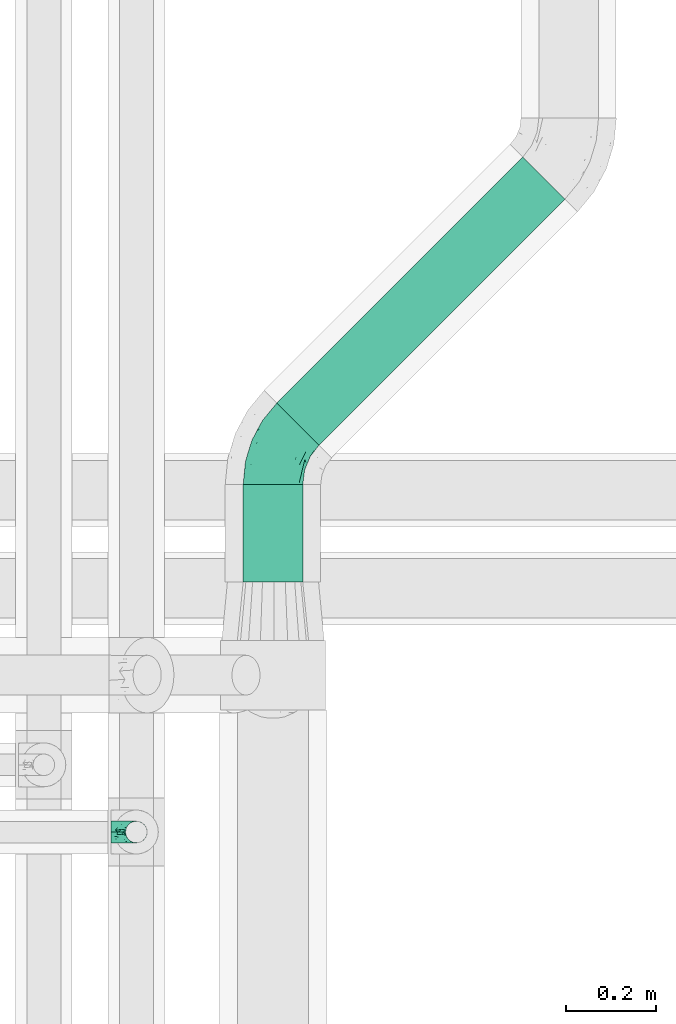
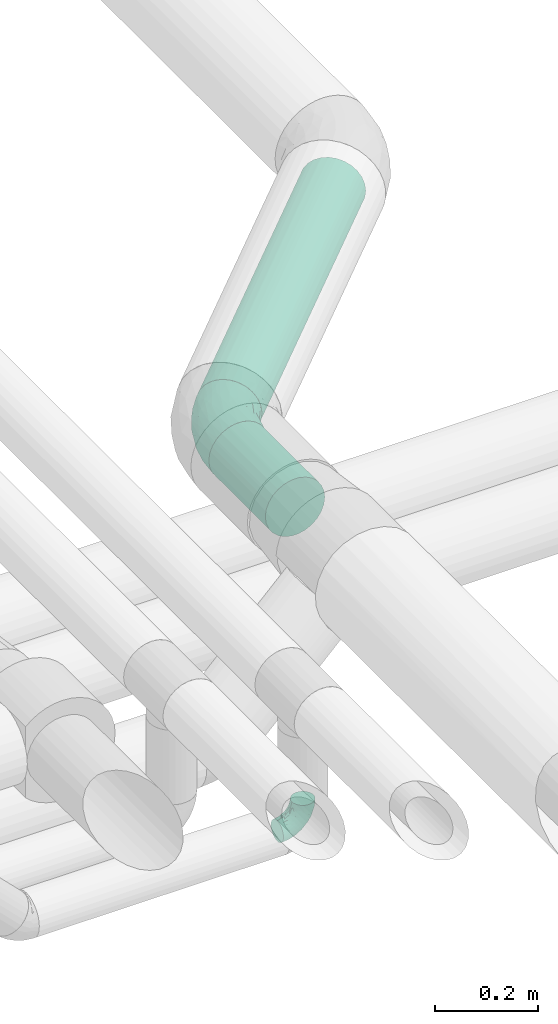
# One storey, part 69 of 93: 2 flow fittings, 2 flow segments.
"""IFC2X3 building model written with IfcOpenShell, lengths in millimetres."""

from ifc_helpers import new_model, entity, si_unit, converted_unit, derived_unit, direction, frame, origin, origin_2d_with_axis, place, context, subcontext, project, spatial, circle, extrude, faceted_brep, source, transform, mapped, material, type_object, type_shapes, element, save


model = new_model("IFC2X3")

# Units and contexts
model_context = context("Model", 3, precision=0.01, world=origin(), true_north=direction((6.12303176911189e-17, 1.0)))
body_context = subcontext(model_context, "Body", "Model", "MODEL_VIEW")
ifc_project = project(units=[si_unit("LENGTHUNIT", "METRE", prefix="MILLI"), si_unit("AREAUNIT", "SQUARE_METRE"), si_unit("VOLUMEUNIT", "CUBIC_METRE"), converted_unit("PLANEANGLEUNIT", "DEGREE", entity("IfcRatioMeasure", 0.0174532925199433), si_unit("PLANEANGLEUNIT", "RADIAN"), dimensions=[0, 0, 0, 0, 0, 0, 0]), si_unit("MASSUNIT", "GRAM", prefix="KILO"), derived_unit("MASSDENSITYUNIT", [(si_unit("MASSUNIT", "GRAM", prefix="KILO"), 1), (si_unit("LENGTHUNIT", "METRE"), -3)]), derived_unit("MOMENTOFINERTIAUNIT", [(si_unit("LENGTHUNIT", "METRE"), 4)]), si_unit("TIMEUNIT", "SECOND"), si_unit("FREQUENCYUNIT", "HERTZ"), si_unit("THERMODYNAMICTEMPERATUREUNIT", "DEGREE_CELSIUS"), derived_unit("THERMALTRANSMITTANCEUNIT", [(si_unit("MASSUNIT", "GRAM", prefix="KILO"), 1), (si_unit("THERMODYNAMICTEMPERATUREUNIT", "KELVIN"), -1), (si_unit("TIMEUNIT", "SECOND"), -3)]), derived_unit("VOLUMETRICFLOWRATEUNIT", [(si_unit("LENGTHUNIT", "METRE"), 3), (si_unit("TIMEUNIT", "SECOND"), -1)]), derived_unit("MASSFLOWRATEUNIT", [(si_unit("MASSUNIT", "GRAM", prefix="KILO"), 1), (si_unit("TIMEUNIT", "SECOND"), -1)]), derived_unit("ROTATIONALFREQUENCYUNIT", [(si_unit("TIMEUNIT", "SECOND"), -1)]), si_unit("ELECTRICCURRENTUNIT", "AMPERE"), si_unit("ELECTRICVOLTAGEUNIT", "VOLT"), si_unit("POWERUNIT", "WATT"), si_unit("FORCEUNIT", "NEWTON", prefix="KILO"), si_unit("ILLUMINANCEUNIT", "LUX"), si_unit("LUMINOUSFLUXUNIT", "LUMEN"), si_unit("LUMINOUSINTENSITYUNIT", "CANDELA"), derived_unit("USERDEFINED", [(si_unit("MASSUNIT", "GRAM", prefix="KILO"), -1), (si_unit("LENGTHUNIT", "METRE"), -2), (si_unit("TIMEUNIT", "SECOND"), 3), (si_unit("LUMINOUSFLUXUNIT", "LUMEN"), 1)]), derived_unit("LINEARVELOCITYUNIT", [(si_unit("LENGTHUNIT", "METRE"), 1), (si_unit("TIMEUNIT", "SECOND"), -1)]), si_unit("PRESSUREUNIT", "PASCAL"), derived_unit("USERDEFINED", [(si_unit("LENGTHUNIT", "METRE"), -2), (si_unit("MASSUNIT", "GRAM", prefix="KILO"), 1), (si_unit("TIMEUNIT", "SECOND"), -2)]), derived_unit("LINEARFORCEUNIT", [(si_unit("MASSUNIT", "GRAM", prefix="KILO"), 1), (si_unit("LENGTHUNIT", "METRE"), 1), (si_unit("TIMEUNIT", "SECOND"), -2), (si_unit("LENGTHUNIT", "METRE"), -1)]), derived_unit("PLANARFORCEUNIT", [(si_unit("MASSUNIT", "GRAM", prefix="KILO"), 1), (si_unit("LENGTHUNIT", "METRE"), 1), (si_unit("TIMEUNIT", "SECOND"), -2), (si_unit("LENGTHUNIT", "METRE"), -2)])], contexts=[model_context])

# Site, building, storey
site_placement = place(None, origin())
site = spatial("IfcSite", under=ifc_project, at=site_placement, CompositionType="ELEMENT")
building_placement = place(site_placement, origin())
building = spatial("IfcBuilding", under=site, at=building_placement, CompositionType="ELEMENT")
storey_placement = place(building_placement, frame((0.0, 0.0, -4200.0)))
storey = spatial("IfcBuildingStorey", under=building, at=storey_placement, CompositionType="ELEMENT", Elevation=-4200.0)

# Flow segments
pipe_segment_type = type_object("IfcPipeSegmentType", PredefinedType="NOTDEFINED")
flow_segment_1_placement = place(storey_placement, frame((24911.2, 9268.64, 2931.9)))
element("IfcFlowSegment", 1, at=flow_segment_1_placement, inside=storey, type_object=pipe_segment_type, context=body_context, shape_type="SweptSolid", body=[
    extrude(circle(Radius=66.5, at=origin_2d_with_axis()), frame((68.1, 0.0, 68.1), z_axis=(0.0, 1.0, 0.0), x_axis=(1.0, 0.0, 0.0)), (0.0, 0.0, 1.0), 218.399081147116),
])
flow_segment_2_placement = place(storey_placement, frame((24986.33, 9572.77, 2931.9)))
element("IfcFlowSegment", 2, at=flow_segment_2_placement, inside=storey, type_object=pipe_segment_type, context=body_context, shape_type="SweptSolid", body=[
    extrude(circle(Radius=66.5, at=origin_2d_with_axis()), frame((48.62, 48.62, 68.1), z_axis=(0.707106781186553, 0.707106781186542, 0.0), x_axis=(0.707106781186542, -0.707106781186553, 0.0)), (0.0, 0.0, 1.0), 775.73593128809),
])

# Flow fittings
ifc_material = material()
pipe_fitting_type_1 = type_object("IfcPipeFittingType", Name="ADSK_2", PredefinedType="NOTDEFINED", material=ifc_material)
shared_shape_1 = source(origin(), body_context, "Body", "Brep", [
    faceted_brep([(-78.7, 33.25, -57.59), (-78.7, 17.21, -64.23), (-78.7, 0.0, -66.5), (-78.7, -17.21, -64.23), (-78.7, -33.25, -57.59), (-78.7, -47.02, -47.02), (-78.7, -57.59, -33.25), (-78.7, -64.23, -17.21), (-78.7, -66.5, 0.0), (-78.7, -64.23, 17.21), (-78.7, -57.59, 33.25), (-78.7, -47.02, 47.02), (-78.7, -33.25, 57.59), (-78.7, -17.21, 64.23), (-78.7, 0.0, 66.5), (-78.7, 17.21, 64.23), (-78.7, 33.25, 57.59), (-78.7, 47.02, 47.02), (-78.7, 57.59, 33.25), (-78.7, 64.23, 17.21), (-78.7, 66.5, 0.0), (-78.7, 64.23, -17.21), (-78.7, 57.59, -33.25), (-78.7, 47.02, -47.02), (55.65, 55.65, -66.5), (43.48, 67.82, -64.23), (32.14, 79.16, -57.59), (22.4, 88.9, -47.02), (14.93, 96.37, -33.25), (10.23, 101.07, -17.21), (8.63, 102.67, 0.0), (10.23, 101.07, 17.21), (14.93, 96.37, 33.25), (22.4, 88.9, 47.02), (32.14, 79.16, 57.59), (43.48, 67.82, 64.23), (55.65, 55.65, 66.5), (67.82, 43.48, 64.23), (79.16, 32.14, 57.59), (88.9, 22.4, 47.02), (96.37, 14.93, 33.25), (101.07, 10.23, 17.21), (102.67, 8.63, 0.0), (101.07, 10.23, -17.21), (96.37, 14.93, -33.25), (88.9, 22.4, -47.02), (79.16, 32.14, -57.59), (67.82, 43.48, -64.23), (-40.01, -57.38, 27.86), (-40.6, -61.75, 15.74), (-6.41, -52.87, 20.07), (-28.66, -61.57, 0.0), (44.74, 12.16, 61.0), (-23.71, -35.12, 51.77), (8.73, -21.07, 54.25), (-40.23, -23.04, 61.0), (-34.61, -49.5, 39.47), (-28.9, -3.87, 65.72), (-8.47, 20.45, 66.18), (-47.15, 10.46, 66.05), (-49.81, 55.22, 41.25), (-33.77, 66.88, 30.79), (-20.88, 50.42, 53.92), (7.4, 48.4, 61.91), (-34.71, 30.07, 61.97), (42.4, -35.06, 11.04), (19.46, -46.98, 0.0), (63.8, -23.27, 0.0), (-15.18, 67.35, 41.6), (14.82, -35.78, 38.27), (53.98, -24.32, 23.88), (-30.55, 73.76, 17.41), (-46.74, 70.71, 0.0), (59.47, -10.53, 39.47), (-16.95, 83.05, 0.0), (25.95, 40.74, 66.05), (41.59, -8.07, 51.77), (23.18, 17.7, 65.72), (74.36, -14.41, 12.26), (4.62, -11.15, 60.44), (-39.45, 28.99, -61.91), (-20.88, 50.42, -53.92), (3.28, 45.81, -61.97), (-23.41, 71.18, -30.79), (8.73, -21.07, -54.25), (4.62, -11.15, -60.44), (44.74, 12.16, -61.0), (-30.55, 73.76, -17.41), (-40.23, -23.04, -61.0), (-23.71, -35.12, -51.77), (-36.89, 58.36, -41.6), (-47.15, 10.46, -66.05), (-28.9, -3.87, -65.72), (-20.98, -55.37, -23.88), (-34.61, -49.5, -39.47), (68.86, -12.28, -27.86), (59.47, -10.53, -39.47), (-42.39, -62.77, -12.26), (41.59, -8.07, -51.77), (14.82, -35.78, -38.27), (41.92, -32.85, -20.07), (-5.19, -54.78, -11.04), (72.37, -14.95, -15.74), (-3.83, 74.27, -41.25), (25.95, 40.74, -66.05), (23.18, 17.7, -65.72), (-8.47, 20.45, -66.18)], [[[0, 1, 2, 3, 4, 5, 6, 7, 8, 9, 10, 11, 12, 13, 14, 15, 16, 17, 18, 19, 20, 21, 22, 23]], [[24, 25, 26, 27, 28, 29, 30, 31, 32, 33, 34, 35, 36, 37, 38, 39, 40, 41, 42, 43, 44, 45, 46, 47]], [[48, 49, 50]], [[49, 8, 51]], [[38, 37, 52]], [[12, 11, 53]], [[53, 54, 55]], [[56, 11, 10]], [[14, 13, 57]], [[13, 12, 55]], [[57, 58, 59]], [[60, 61, 18]], [[62, 63, 34]], [[18, 61, 19]], [[16, 15, 64]], [[17, 16, 62]], [[65, 66, 67]], [[60, 62, 68]], [[15, 14, 59]], [[34, 33, 62]], [[69, 50, 70]], [[19, 71, 72]], [[40, 39, 73]], [[72, 20, 19]], [[74, 71, 31]], [[50, 66, 65]], [[62, 16, 64]], [[56, 48, 69]], [[66, 50, 51]], [[36, 35, 75]], [[39, 38, 76]], [[76, 73, 39]], [[32, 31, 61]], [[75, 77, 36]], [[70, 41, 40]], [[77, 37, 36]], [[48, 56, 10]], [[70, 40, 73]], [[59, 64, 15]], [[76, 38, 52]], [[58, 75, 63]], [[42, 41, 78]], [[53, 56, 69]], [[17, 60, 18]], [[54, 79, 55]], [[72, 71, 74]], [[48, 9, 49]], [[30, 74, 31]], [[54, 69, 76]], [[31, 71, 61]], [[58, 57, 77]], [[32, 68, 33]], [[55, 57, 13]], [[68, 62, 33]], [[79, 52, 77]], [[35, 34, 63]], [[63, 62, 64]], [[73, 76, 69]], [[79, 77, 57]], [[78, 70, 65]], [[70, 73, 69]], [[56, 53, 11]], [[58, 63, 64]], [[53, 55, 12]], [[57, 55, 79]], [[77, 52, 37]], [[52, 79, 54]], [[57, 59, 14]], [[64, 59, 58]], [[63, 75, 35]], [[77, 75, 58]], [[62, 60, 17]], [[61, 60, 68]], [[32, 61, 68]], [[61, 71, 19]], [[9, 48, 10]], [[69, 48, 50]], [[8, 49, 9]], [[51, 50, 49]], [[78, 65, 67]], [[50, 65, 70]], [[42, 78, 67]], [[70, 78, 41]], [[69, 54, 53]], [[52, 54, 76]], [[1, 0, 80]], [[81, 82, 80]], [[28, 83, 29]], [[23, 81, 0]], [[20, 72, 21]], [[84, 85, 86]], [[21, 87, 83]], [[88, 89, 4]], [[81, 23, 90]], [[91, 92, 2]], [[26, 25, 82]], [[91, 2, 1]], [[93, 6, 94]], [[95, 96, 44]], [[8, 7, 97]], [[81, 80, 0]], [[93, 7, 6]], [[98, 96, 99]], [[88, 4, 3]], [[100, 66, 101]], [[6, 5, 94]], [[89, 5, 4]], [[2, 92, 3]], [[94, 89, 99]], [[93, 94, 99]], [[96, 98, 45]], [[87, 72, 74]], [[89, 94, 5]], [[74, 30, 29]], [[99, 100, 93]], [[72, 87, 21]], [[95, 43, 102]], [[103, 83, 28]], [[90, 103, 81]], [[26, 82, 81]], [[46, 45, 98]], [[104, 25, 24]], [[96, 95, 99]], [[22, 90, 23]], [[26, 81, 27]], [[84, 99, 89]], [[104, 105, 106]], [[84, 86, 98]], [[27, 103, 28]], [[24, 47, 105]], [[67, 66, 100]], [[44, 96, 45]], [[47, 46, 86]], [[100, 95, 102]], [[85, 92, 105]], [[67, 102, 42]], [[85, 88, 92]], [[106, 105, 92]], [[97, 93, 101]], [[22, 21, 83]], [[101, 66, 51]], [[104, 82, 25]], [[87, 74, 29]], [[106, 91, 80]], [[86, 105, 47]], [[106, 80, 82]], [[92, 88, 3]], [[88, 85, 84]], [[98, 86, 46]], [[105, 86, 85]], [[80, 91, 1]], [[92, 91, 106]], [[105, 104, 24]], [[82, 104, 106]], [[81, 103, 27]], [[83, 103, 90]], [[22, 83, 90]], [[83, 87, 29]], [[43, 95, 44]], [[99, 95, 100]], [[42, 102, 43]], [[67, 100, 102]], [[97, 101, 51]], [[100, 101, 93]], [[8, 97, 51]], [[93, 97, 7]], [[99, 84, 98]], [[88, 84, 89]]]),
])
type_shapes(pipe_fitting_type_1, [shared_shape_1])
flow_fitting_1_placement = place(storey_placement, frame((24979.3, 9565.74, 3000.0), z_axis=(0.0, 0.0, 1.0), x_axis=(-0.707106781186546, -0.70710678118655, 0.0)))
element("IfcFlowFitting", 3, at=flow_fitting_1_placement, inside=storey, type_object=pipe_fitting_type_1, material=ifc_material, Name="ADSK_2", ObjectType="ADSK_2", context=body_context, shape_type="MappedRepresentation", body=[
    mapped(shared_shape_1, transform((0.0, 0.0, 0.0), scale=1.0)),
])
pipe_fitting_type_2 = type_object("IfcPipeFittingType", Name="ADSK_1", PredefinedType="NOTDEFINED", material=ifc_material)
shared_shape_2 = source(origin(), body_context, "Body", "Brep", [
    faceted_brep([(-57.0, 12.07, -20.91), (-57.0, 6.25, -23.33), (-57.0, 0.0, -24.15), (-57.0, -6.25, -23.33), (-57.0, -12.08, -20.91), (-57.0, -17.08, -17.08), (-57.0, -20.91, -12.08), (-57.0, -23.33, -6.25), (-57.0, -24.15, 0.0), (-57.0, -23.33, 6.25), (-57.0, -20.91, 12.07), (-57.0, -17.08, 17.08), (-57.0, -12.08, 20.91), (-57.0, -6.25, 23.33), (-57.0, 0.0, 24.15), (-57.0, 6.25, 23.33), (-57.0, 12.07, 20.91), (-57.0, 17.08, 17.08), (-57.0, 20.91, 12.07), (-57.0, 23.33, 6.25), (-57.0, 24.15, 0.0), (-57.0, 23.33, -6.25), (-57.0, 20.91, -12.08), (-57.0, 17.08, -17.08), (0.0, 57.0, -24.15), (-6.25, 57.0, -23.33), (-12.07, 57.0, -20.91), (-17.08, 57.0, -17.08), (-20.91, 57.0, -12.08), (-23.33, 57.0, -6.25), (-24.15, 57.0, 0.0), (-23.33, 57.0, 6.25), (-20.91, 57.0, 12.07), (-17.08, 57.0, 17.08), (-12.07, 57.0, 20.91), (-6.25, 57.0, 23.33), (0.0, 57.0, 24.15), (6.25, 57.0, 23.33), (12.08, 57.0, 20.91), (17.08, 57.0, 17.08), (20.91, 57.0, 12.07), (23.33, 57.0, 6.25), (24.15, 57.0, 0.0), (23.33, 57.0, -6.25), (20.91, 57.0, -12.08), (17.08, 57.0, -17.08), (12.08, 57.0, -20.91), (6.25, 57.0, -23.33), (14.9, 21.14, 6.17), (13.61, 24.64, 12.48), (6.23, 8.95, 8.98), (-41.47, -21.06, 0.0), (-41.92, -18.38, 13.72), (-24.64, -13.61, 12.48), (-37.37, -13.24, 18.15), (-6.8, -4.93, 8.18), (-21.76, -15.19, 6.22), (-12.78, -9.18, 0.0), (-37.73, -20.51, 7.75), (-7.38, 7.38, 20.24), (-23.37, -4.26, 20.42), (-11.9, -3.19, 15.86), (-42.14, -8.7, 21.82), (13.24, 37.37, 18.15), (9.33, 23.53, 16.85), (4.26, 23.37, 20.42), (2.77, 10.92, 15.55), (-29.46, 0.91, 23.52), (-44.13, 20.56, 15.69), (-39.25, 26.33, 10.88), (-49.02, 22.92, 9.96), (-34.58, 23.87, 17.15), (-15.8, 6.8, 22.81), (-8.67, 20.47, 23.88), (-18.12, 12.9, 24.08), (-48.29, 14.92, 19.65), (-44.06, -2.85, 23.78), (-9.23, 48.95, 22.58), (-3.78, 42.74, 24.07), (-40.34, 4.26, 24.09), (-44.02, 26.14, 5.46), (-44.04, 9.88, 22.74), (-4.95, 16.87, 22.52), (-2.75, 1.43, 12.5), (-25.48, 40.98, 10.71), (20.51, 37.73, 7.75), (18.38, 41.92, 13.72), (8.7, 42.14, 21.82), (-25.95, -17.97, 0.0), (2.85, 44.06, 23.78), (21.06, 41.47, 0.0), (17.97, 25.95, 0.0), (-24.04, -9.27, 17.13), (-33.26, 33.26, 5.86), (-28.55, 40.57, 0.0), (-40.57, 28.55, 0.0), (-25.29, 47.19, 4.06), (-27.01, 31.1, 16.77), (-15.7, 43.95, 19.9), (-20.27, 45.22, 15.61), (-30.53, 31.98, 12.64), (-11.28, 38.33, 22.92), (-9.97, 27.88, 24.09), (-20.15, 30.26, 21.25), (-31.25, 11.75, 23.64), (-28.75, 7.23, 24.15), (-29.53, 18.06, 22.27), (-28.44, 24.21, 20.02), (-37.55, 17.7, 20.26), (-15.88, 29.25, 22.99), (-20.82, 20.82, 23.44), (-0.91, 29.46, 23.52), (-13.5, -7.67, 12.04), (1.49, 1.56, 5.16), (8.86, 10.35, 4.59), (0.38, -0.38, 0.0), (9.18, 12.78, 0.0), (-37.37, -13.24, -18.15), (8.86, 10.35, -4.59), (-45.22, 20.27, -15.61), (-43.95, 15.7, -19.9), (-38.33, 11.28, -22.92), (-48.95, 9.23, -22.58), (-47.19, 25.29, -4.06), (-33.26, 33.26, -5.86), (18.38, 41.92, -13.72), (-30.26, 20.15, -21.25), (2.85, 44.06, -23.78), (-4.26, 40.34, -24.09), (-40.98, 25.48, -10.71), (-41.92, -18.38, -13.72), (9.25, 23.5, -16.92), (4.26, 23.37, -20.42), (13.24, 37.37, -18.15), (-37.73, -20.51, -7.75), (-11.75, 31.25, -23.64), (-7.23, 28.75, -24.15), (-12.9, 18.12, -24.08), (8.7, 42.14, -21.82), (-44.06, -2.85, -23.78), (-6.8, 15.8, -22.81), (-20.47, 8.67, -23.88), (-24.64, -13.61, -12.48), (-42.74, 3.78, -24.07), (-18.06, 29.53, -22.27), (-24.21, 28.44, -20.02), (-27.88, 9.97, -24.09), (-31.1, 27.01, -16.77), (-26.14, 44.02, -5.46), (14.9, 21.14, -6.17), (20.51, 37.73, -7.75), (-9.88, 44.04, -22.74), (-20.56, 44.13, -15.69), (-21.76, -15.19, -6.22), (-13.5, -7.67, -12.04), (-24.14, -9.76, -16.74), (-11.9, -3.19, -15.86), (-14.92, 48.29, -19.65), (-23.37, -4.26, -20.42), (-0.91, 29.46, -23.52), (-26.33, 39.25, -10.88), (-23.87, 34.58, -17.15), (-42.14, -8.7, -21.82), (-22.92, 49.02, -9.96), (13.61, 24.64, -12.48), (-31.98, 30.53, -12.64), (-16.87, 4.95, -22.52), (-17.7, 37.55, -20.26), (-29.25, 15.88, -22.99), (-20.82, 20.82, -23.44), (-29.46, 0.91, -23.52), (-7.38, 7.38, -20.24), (2.77, 10.92, -15.55), (6.23, 8.95, -8.98), (-6.8, -4.93, -8.18), (-2.81, 1.41, -12.54), (1.49, 1.56, -5.16)], [[[0, 1, 2, 3, 4, 5, 6, 7, 8, 9, 10, 11, 12, 13, 14, 15, 16, 17, 18, 19, 20, 21, 22, 23]], [[24, 25, 26, 27, 28, 29, 30, 31, 32, 33, 34, 35, 36, 37, 38, 39, 40, 41, 42, 43, 44, 45, 46, 47]], [[48, 49, 50]], [[9, 8, 51]], [[52, 53, 54]], [[55, 56, 57]], [[10, 58, 52]], [[9, 58, 10]], [[59, 60, 61]], [[54, 12, 11]], [[54, 62, 12]], [[63, 39, 38]], [[64, 65, 66]], [[62, 60, 67]], [[68, 69, 70]], [[71, 69, 68]], [[72, 73, 74]], [[16, 75, 17]], [[13, 76, 14]], [[35, 77, 78]], [[14, 79, 15]], [[17, 68, 18]], [[14, 76, 79]], [[20, 19, 80]], [[70, 19, 18]], [[81, 15, 79]], [[15, 81, 16]], [[73, 72, 82]], [[66, 83, 50]], [[32, 31, 84]], [[85, 86, 49]], [[63, 87, 65]], [[56, 58, 88]], [[36, 89, 37]], [[85, 41, 40]], [[36, 35, 78]], [[90, 41, 85]], [[40, 39, 86]], [[12, 62, 13]], [[86, 85, 40]], [[48, 85, 49]], [[85, 91, 90]], [[87, 38, 37]], [[92, 60, 54]], [[80, 69, 93]], [[93, 94, 95]], [[10, 52, 11]], [[94, 96, 30]], [[97, 98, 99]], [[80, 93, 95]], [[100, 97, 84]], [[99, 98, 33]], [[101, 102, 78]], [[103, 101, 98]], [[96, 31, 30]], [[77, 98, 101]], [[77, 35, 34]], [[34, 33, 98]], [[9, 51, 58]], [[87, 63, 38]], [[104, 105, 74]], [[106, 103, 107]], [[106, 81, 104]], [[75, 68, 17]], [[108, 107, 71]], [[33, 32, 99]], [[109, 103, 110]], [[101, 109, 102]], [[89, 78, 111]], [[53, 52, 58]], [[54, 11, 52]], [[60, 62, 54]], [[88, 58, 51]], [[76, 62, 67]], [[53, 112, 92]], [[60, 59, 72]], [[39, 63, 86]], [[49, 86, 63]], [[89, 87, 37]], [[42, 41, 90]], [[111, 82, 65]], [[111, 65, 87]], [[65, 59, 66]], [[104, 81, 79]], [[75, 81, 108]], [[32, 84, 99]], [[97, 99, 84]], [[98, 97, 103]], [[106, 107, 108]], [[74, 102, 110]], [[111, 78, 102]], [[74, 110, 104]], [[74, 67, 72]], [[61, 92, 112]], [[66, 59, 61]], [[56, 53, 58]], [[66, 50, 49]], [[61, 112, 83]], [[66, 49, 64]], [[78, 89, 36]], [[87, 89, 111]], [[62, 76, 13]], [[79, 76, 67]], [[100, 93, 69]], [[96, 93, 84]], [[55, 113, 50]], [[113, 114, 50]], [[104, 79, 105]], [[106, 104, 110]], [[20, 80, 95]], [[85, 48, 91]], [[115, 114, 113]], [[116, 91, 48]], [[70, 80, 19]], [[93, 96, 94]], [[84, 31, 96]], [[103, 106, 110]], [[81, 106, 108]], [[103, 97, 107]], [[71, 107, 97]], [[71, 97, 100]], [[108, 71, 68]], [[79, 67, 105]], [[67, 74, 105]], [[115, 113, 57]], [[112, 56, 55]], [[56, 88, 57]], [[60, 72, 67]], [[82, 72, 59]], [[65, 82, 59]], [[82, 111, 73]], [[111, 102, 73]], [[102, 74, 73]], [[81, 75, 16]], [[68, 75, 108]], [[68, 70, 18]], [[80, 70, 69]], [[98, 77, 34]], [[78, 77, 101]], [[93, 100, 84]], [[71, 100, 69]], [[102, 109, 110]], [[101, 103, 109]], [[53, 92, 54]], [[61, 60, 92]], [[56, 112, 53]], [[83, 112, 55]], [[50, 83, 55]], [[61, 83, 66]], [[49, 63, 64]], [[65, 64, 63]], [[57, 113, 55]], [[114, 115, 116]], [[116, 48, 114]], [[48, 50, 114]], [[117, 5, 4]], [[116, 115, 118]], [[119, 120, 23]], [[121, 122, 120]], [[95, 123, 20]], [[0, 23, 120]], [[124, 95, 94]], [[125, 45, 44]], [[121, 120, 126]], [[24, 127, 128]], [[22, 21, 129]], [[0, 122, 1]], [[5, 117, 130]], [[131, 132, 133]], [[134, 88, 51]], [[135, 136, 137]], [[6, 5, 130]], [[46, 138, 47]], [[139, 3, 2]], [[140, 141, 137]], [[6, 134, 7]], [[134, 130, 142]], [[143, 2, 1]], [[144, 126, 145]], [[121, 146, 143]], [[147, 120, 119]], [[94, 148, 124]], [[149, 150, 91]], [[30, 29, 148]], [[151, 25, 128]], [[27, 152, 28]], [[134, 153, 88]], [[154, 155, 156]], [[27, 26, 157]], [[151, 26, 25]], [[155, 158, 156]], [[24, 47, 127]], [[1, 122, 143]], [[138, 132, 159]], [[160, 152, 161]], [[24, 128, 25]], [[46, 133, 138]], [[162, 117, 4]], [[148, 160, 124]], [[152, 160, 163]], [[154, 142, 155]], [[45, 125, 133]], [[133, 46, 45]], [[125, 164, 133]], [[51, 7, 134]], [[42, 90, 43]], [[165, 147, 129]], [[153, 134, 142]], [[43, 150, 44]], [[162, 4, 3]], [[141, 140, 166]], [[117, 162, 158]], [[163, 29, 28]], [[43, 90, 150]], [[123, 21, 20]], [[144, 151, 135]], [[157, 152, 27]], [[167, 145, 161]], [[23, 22, 119]], [[168, 126, 169]], [[121, 168, 146]], [[139, 143, 170]], [[142, 130, 117]], [[8, 7, 51]], [[134, 6, 130]], [[139, 162, 3]], [[170, 166, 158]], [[170, 158, 162]], [[158, 171, 156]], [[44, 150, 125]], [[91, 150, 90]], [[164, 125, 150]], [[132, 138, 133]], [[127, 138, 159]], [[131, 164, 172]], [[132, 171, 140]], [[135, 151, 128]], [[157, 151, 167]], [[22, 129, 119]], [[147, 119, 129]], [[120, 147, 126]], [[144, 145, 167]], [[137, 146, 169]], [[170, 143, 146]], [[137, 169, 135]], [[137, 159, 140]], [[171, 172, 156]], [[173, 174, 175]], [[156, 175, 154]], [[174, 57, 153]], [[132, 172, 171]], [[172, 164, 173]], [[143, 139, 2]], [[162, 139, 170]], [[138, 127, 47]], [[128, 127, 159]], [[165, 124, 160]], [[123, 124, 129]], [[149, 173, 164]], [[176, 174, 173]], [[135, 128, 136]], [[144, 135, 169]], [[150, 149, 164]], [[176, 118, 115]], [[149, 91, 116]], [[30, 148, 94]], [[163, 148, 29]], [[124, 123, 95]], [[129, 21, 123]], [[126, 144, 169]], [[151, 144, 167]], [[126, 147, 145]], [[161, 145, 147]], [[161, 147, 165]], [[167, 161, 152]], [[128, 159, 136]], [[159, 137, 136]], [[154, 153, 142]], [[132, 140, 159]], [[174, 176, 57]], [[57, 88, 153]], [[166, 140, 171]], [[158, 166, 171]], [[166, 170, 141]], [[170, 146, 141]], [[146, 137, 141]], [[151, 157, 26]], [[152, 157, 167]], [[152, 163, 28]], [[148, 163, 160]], [[120, 122, 0]], [[143, 122, 121]], [[124, 165, 129]], [[161, 165, 160]], [[146, 168, 169]], [[121, 126, 168]], [[142, 117, 155]], [[158, 155, 117]], [[175, 156, 172]], [[153, 154, 174]], [[173, 175, 172]], [[174, 154, 175]], [[164, 131, 133]], [[172, 132, 131]], [[176, 173, 118]], [[57, 176, 115]], [[173, 149, 118]], [[149, 116, 118]]]),
])
type_shapes(pipe_fitting_type_2, [shared_shape_2])
flow_fitting_2_placement = place(storey_placement, frame((24674.46, 8711.14, 2700.0), z_axis=(0.0, 1.0, 0.0), x_axis=(0.0, 0.0, -1.0)))
element("IfcFlowFitting", 4, at=flow_fitting_2_placement, inside=storey, type_object=pipe_fitting_type_2, material=ifc_material, Name="ADSK_1", ObjectType="ADSK_1", context=body_context, shape_type="MappedRepresentation", body=[
    mapped(shared_shape_2, transform((0.0, 0.0, 0.0), scale=1.0)),
])

save(model, "model.ifc")
